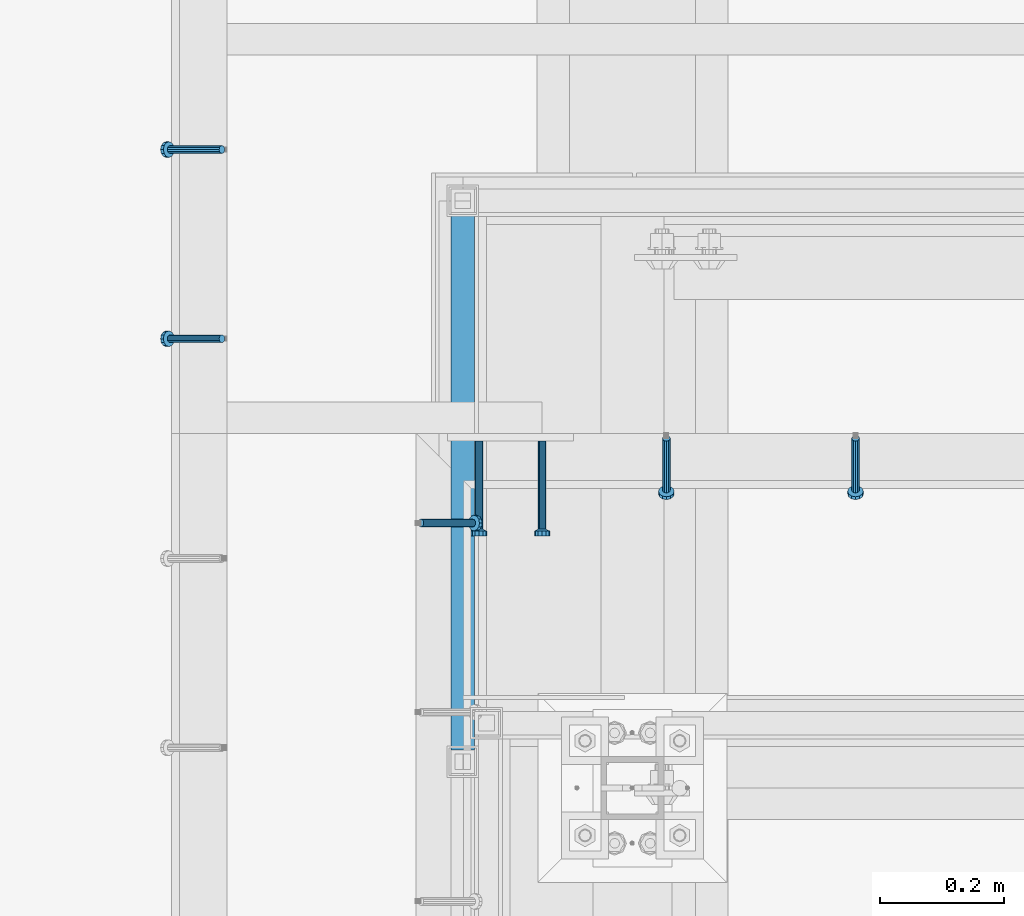
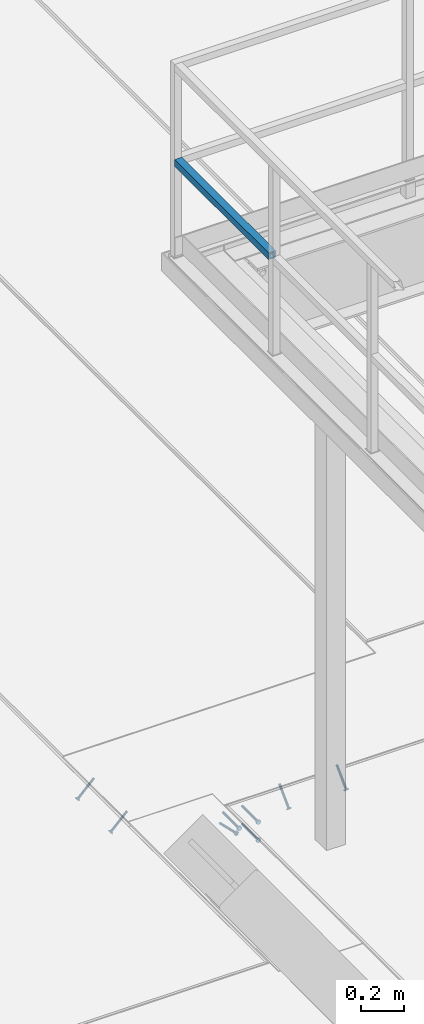
# One storey, part 2117 of 3843: 5 members, 4 beams, 5 elements without a shape of their own.
"""IFC2X3 building model written with IfcOpenShell, lengths in millimetres."""

from ifc_helpers import new_model, si_unit, frame, origin_with_axes, place, context, subcontext, project, spatial, faceted_brep, material, type_object, element, aggregate, save


model = new_model("IFC2X3")

# Units and contexts
model_context = context("Model", 3, precision=1e-05, world=origin_with_axes())
body_context = subcontext(model_context, "Body", "Model", "MODEL_VIEW")
ifc_project = project(units=[si_unit("LENGTHUNIT", "METRE", prefix="MILLI"), si_unit("AREAUNIT", "SQUARE_METRE"), si_unit("VOLUMEUNIT", "CUBIC_METRE"), si_unit("MASSUNIT", "GRAM", prefix="KILO"), si_unit("TIMEUNIT", "SECOND"), si_unit("PLANEANGLEUNIT", "RADIAN"), si_unit("SOLIDANGLEUNIT", "STERADIAN"), si_unit("THERMODYNAMICTEMPERATUREUNIT", "DEGREE_CELSIUS"), si_unit("LUMINOUSINTENSITYUNIT", "LUMEN")], contexts=[model_context])

# Site, building, storey
site_placement = place(None, origin_with_axes())
site = spatial("IfcSite", under=ifc_project, at=site_placement, CompositionType="ELEMENT")
building_placement = place(site_placement, origin_with_axes())
building = spatial("IfcBuilding", under=site, at=building_placement, Name="Undefined", CompositionType="ELEMENT")
storey_placement = place(building_placement, origin_with_axes())
storey = spatial("IfcBuildingStorey", under=building, at=storey_placement, Name="Undefined", CompositionType="ELEMENT", Elevation=0.0)

# Assembly, member
assembly_1_placement = place(storey_placement, origin_with_axes())
assembly_1 = element("IfcElementAssembly", 1, at=assembly_1_placement, inside=storey, Name="EMBED_ANGLE", AssemblyPlace="NOTDEFINED", PredefinedType="RIGID_FRAME")
ifc_material_1 = material(Name="STEEL/A108")
member_type = type_object("IfcMemberType", PredefinedType="NOTDEFINED")
member_1_placement = place(assembly_1_placement, frame((48656.0495, 28024.1375, 30446.6625), z_axis=(0.0, 1.0, 0.0), x_axis=(0.707106781186548, 0.0, -0.707106781186548)))
member_1 = element("IfcMember", 2, at=member_1_placement, type_object=member_type, material=ifc_material_1, Name="HEADED STUD ANCHOR", context=body_context, shape_type="Brep", body=[
    faceted_brep([(7.27595761418343e-12, -3.18000006675175, 5.5), (0.0, -5.49999999998363, 3.1800000667572), (118.110000000976, -5.49999999999091, 3.1800000667572), (118.110000000983, -3.18000006675175, 5.5), (0.0, -6.3499999046162, 0.0), (118.110000000968, -6.34999990461256, 0.0), (0.0, -5.49999999998363, -3.1800000667572), (118.110000000976, -5.49999999999091, -3.1800000667572), (7.27595761418343e-12, -3.18000006675175, -5.5), (118.110000000983, -3.18000006675175, -5.5), (7.27595761418343e-12, -1.81898940354586e-12, -6.34999990463257), (118.110000000968, -1.81898940354586e-12, -6.34999990463257), (0.0, 3.18000006675175, -5.5), (118.110000000968, 3.18000006674811, -5.5), (7.27595761418343e-12, 5.49999999998363, -3.1800000667572), (118.110000000983, 5.49999999998363, -3.1800000667572), (7.27595761418343e-12, 6.3499999046162, 0.0), (118.110000000976, 6.34999990461256, 0.0), (7.27595761418343e-12, 5.49999999998363, 3.1800000667572), (118.110000000983, 5.49999999998363, 3.1800000667572), (0.0, 3.18000006675175, 5.5), (118.110000000968, 3.18000006674811, 5.5), (7.27595761418343e-12, -1.81898940354586e-12, 6.34999990463257), (118.110000000968, -1.81898940354586e-12, 6.34999990463257), (120.650000000991, -10.9899997710909, 6.34999990463257), (120.650000000998, -6.34000015257152, 10.9899997711182), (120.650000000991, -12.6999998092379, 0.0), (120.650000000991, -10.9899997710909, -6.34999990463257), (120.650000000998, -6.34000015257152, -10.9899997711182), (120.650000000991, -1.81898940354586e-12, -12.6899995803833), (120.650000000991, 6.34000015257152, -10.9899997711182), (120.650000000998, 10.9899997710909, -6.34999990463257), (120.650000000991, 12.6999998092342, 0.0), (120.650000000998, 10.9899997710909, 6.34999990463257), (120.650000000991, 6.34000015257152, 10.9899997711182), (120.650000000991, -1.81898940354586e-12, 12.6899995803833), (127.000000001048, -10.9899997710945, 6.34999990463257), (127.000000001048, -6.34000015257152, 10.9899997711182), (127.000000001048, -12.6999998092342, 0.0), (127.000000001048, -10.9899997710945, -6.34999990463257), (127.000000001048, -6.34000015257152, -10.9899997711182), (127.000000001048, 1.81898940354586e-12, -12.6899995803833), (127.000000001048, 6.34000015256788, -10.9899997711182), (127.000000001048, 10.9899997710909, -6.34999990463257), (127.000000001048, 12.6999998092379, 0.0), (127.000000001048, 10.9899997710909, 6.34999990463257), (127.000000001048, 6.34000015256788, 10.9899997711182), (127.000000001048, 1.81898940354586e-12, 12.6899995803833)], [[[0, 1, 2, 3]], [[1, 4, 5, 2]], [[4, 6, 7, 5]], [[6, 8, 9, 7]], [[8, 10, 11, 9]], [[10, 12, 13, 11]], [[12, 14, 15, 13]], [[14, 16, 17, 15]], [[16, 18, 19, 17]], [[18, 20, 21, 19]], [[20, 22, 23, 21]], [[22, 0, 3, 23]], [[22, 20, 18, 16, 14, 12, 10, 8, 6, 4, 1, 0]], [[3, 2, 24, 25]], [[2, 5, 26, 24]], [[5, 7, 27, 26]], [[7, 9, 28, 27]], [[9, 11, 29, 28]], [[11, 13, 30, 29]], [[13, 15, 31, 30]], [[15, 17, 32, 31]], [[17, 19, 33, 32]], [[19, 21, 34, 33]], [[21, 23, 35, 34]], [[23, 3, 25, 35]], [[25, 24, 36, 37]], [[24, 26, 38, 36]], [[26, 27, 39, 38]], [[27, 28, 40, 39]], [[28, 29, 41, 40]], [[29, 30, 42, 41]], [[30, 31, 43, 42]], [[31, 32, 44, 43]], [[32, 33, 45, 44]], [[33, 34, 46, 45]], [[34, 35, 47, 46]], [[35, 25, 37, 47]], [[38, 39, 40, 41, 42, 43, 44, 45, 46, 47, 37, 36]]]),
])
aggregate(assembly_1, [member_1])

# Assembly, members
assembly_2_placement = place(storey_placement, origin_with_axes())
assembly_2 = element("IfcElementAssembly", 3, at=assembly_2_placement, inside=storey, Name="EMBED_ANGLE", AssemblyPlace="NOTDEFINED", PredefinedType="RIGID_FRAME")
member_2_placement = place(assembly_2_placement, frame((49356.137, 28160.6625, 30446.6625), z_axis=(-1.0, 0.0, 0.0), x_axis=(0.0, -0.707106781186548, -0.707106781186548)))
member_2 = element("IfcMember", 4, at=member_2_placement, type_object=member_type, material=ifc_material_1, Name="HEADED STUD ANCHOR", context=body_context, shape_type="Brep", body=[
    faceted_brep([(7.27595761418343e-12, -3.18000006675175, 5.5), (0.0, -5.49999999998363, 3.1800000667572), (118.110000000976, -5.49999999999091, 3.1800000667572), (118.110000000983, -3.18000006675175, 5.5), (0.0, -6.3499999046162, 0.0), (118.110000000968, -6.34999990461256, 0.0), (0.0, -5.49999999998363, -3.1800000667572), (118.110000000976, -5.49999999999091, -3.1800000667572), (7.27595761418343e-12, -3.18000006675175, -5.5), (118.110000000983, -3.18000006675175, -5.5), (7.27595761418343e-12, -1.81898940354586e-12, -6.34999990463257), (118.110000000968, -1.81898940354586e-12, -6.34999990463257), (0.0, 3.18000006675175, -5.5), (118.110000000968, 3.18000006674811, -5.5), (7.27595761418343e-12, 5.49999999998363, -3.1800000667572), (118.110000000983, 5.49999999998363, -3.1800000667572), (7.27595761418343e-12, 6.3499999046162, 0.0), (118.110000000976, 6.34999990461256, 0.0), (7.27595761418343e-12, 5.49999999998363, 3.1800000667572), (118.110000000983, 5.49999999998363, 3.1800000667572), (0.0, 3.18000006675175, 5.5), (118.110000000968, 3.18000006674811, 5.5), (7.27595761418343e-12, -1.81898940354586e-12, 6.34999990463257), (118.110000000968, -1.81898940354586e-12, 6.34999990463257), (120.650000000991, -10.9899997710909, 6.34999990463257), (120.650000000998, -6.34000015257152, 10.9899997711182), (120.650000000991, -12.6999998092379, 0.0), (120.650000000991, -10.9899997710909, -6.34999990463257), (120.650000000998, -6.34000015257152, -10.9899997711182), (120.650000000991, -1.81898940354586e-12, -12.6899995803833), (120.650000000991, 6.34000015257152, -10.9899997711182), (120.650000000998, 10.9899997710909, -6.34999990463257), (120.650000000991, 12.6999998092342, 0.0), (120.650000000998, 10.9899997710909, 6.34999990463257), (120.650000000991, 6.34000015257152, 10.9899997711182), (120.650000000991, -1.81898940354586e-12, 12.6899995803833), (127.000000001048, -10.9899997710945, 6.34999990463257), (127.000000001048, -6.34000015257152, 10.9899997711182), (127.000000001048, -12.6999998092342, 0.0), (127.000000001048, -10.9899997710945, -6.34999990463257), (127.000000001048, -6.34000015257152, -10.9899997711182), (127.000000001048, 1.81898940354586e-12, -12.6899995803833), (127.000000001048, 6.34000015256788, -10.9899997711182), (127.000000001048, 10.9899997710909, -6.34999990463257), (127.000000001048, 12.6999998092379, 0.0), (127.000000001048, 10.9899997710909, 6.34999990463257), (127.000000001048, 6.34000015256788, 10.9899997711182), (127.000000001048, 1.81898940354586e-12, 12.6899995803833)], [[[0, 1, 2, 3]], [[1, 4, 5, 2]], [[4, 6, 7, 5]], [[6, 8, 9, 7]], [[8, 10, 11, 9]], [[10, 12, 13, 11]], [[12, 14, 15, 13]], [[14, 16, 17, 15]], [[16, 18, 19, 17]], [[18, 20, 21, 19]], [[20, 22, 23, 21]], [[22, 0, 3, 23]], [[22, 20, 18, 16, 14, 12, 10, 8, 6, 4, 1, 0]], [[3, 2, 24, 25]], [[2, 5, 26, 24]], [[5, 7, 27, 26]], [[7, 9, 28, 27]], [[9, 11, 29, 28]], [[11, 13, 30, 29]], [[13, 15, 31, 30]], [[15, 17, 32, 31]], [[17, 19, 33, 32]], [[19, 21, 34, 33]], [[21, 23, 35, 34]], [[23, 3, 25, 35]], [[25, 24, 36, 37]], [[24, 26, 38, 36]], [[26, 27, 39, 38]], [[27, 28, 40, 39]], [[28, 29, 41, 40]], [[29, 30, 42, 41]], [[30, 31, 43, 42]], [[31, 32, 44, 43]], [[32, 33, 45, 44]], [[33, 34, 46, 45]], [[34, 35, 47, 46]], [[35, 25, 37, 47]], [[38, 39, 40, 41, 42, 43, 44, 45, 46, 47, 37, 36]]]),
])
member_3_placement = place(assembly_2_placement, frame((49051.337, 28160.6625, 30446.6625), z_axis=(-1.0, 0.0, 0.0), x_axis=(0.0, -0.707106781186548, -0.707106781186548)))
member_3 = element("IfcMember", 5, at=member_3_placement, type_object=member_type, material=ifc_material_1, Name="HEADED STUD ANCHOR", context=body_context, shape_type="Brep", body=[
    faceted_brep([(7.27595761418343e-12, -3.18000006675175, 5.5), (0.0, -5.49999999998363, 3.1800000667572), (118.110000000976, -5.49999999999091, 3.1800000667572), (118.110000000983, -3.18000006675175, 5.5), (0.0, -6.3499999046162, 0.0), (118.110000000968, -6.34999990461256, 0.0), (0.0, -5.49999999998363, -3.1800000667572), (118.110000000976, -5.49999999999091, -3.1800000667572), (7.27595761418343e-12, -3.18000006675175, -5.5), (118.110000000983, -3.18000006675175, -5.5), (7.27595761418343e-12, -1.81898940354586e-12, -6.34999990463257), (118.110000000968, -1.81898940354586e-12, -6.34999990463257), (0.0, 3.18000006675175, -5.5), (118.110000000968, 3.18000006674811, -5.5), (7.27595761418343e-12, 5.49999999998363, -3.1800000667572), (118.110000000983, 5.49999999998363, -3.1800000667572), (7.27595761418343e-12, 6.3499999046162, 0.0), (118.110000000976, 6.34999990461256, 0.0), (7.27595761418343e-12, 5.49999999998363, 3.1800000667572), (118.110000000983, 5.49999999998363, 3.1800000667572), (0.0, 3.18000006675175, 5.5), (118.110000000968, 3.18000006674811, 5.5), (7.27595761418343e-12, -1.81898940354586e-12, 6.34999990463257), (118.110000000968, -1.81898940354586e-12, 6.34999990463257), (120.650000000991, -10.9899997710909, 6.34999990463257), (120.650000000998, -6.34000015257152, 10.9899997711182), (120.650000000991, -12.6999998092379, 0.0), (120.650000000991, -10.9899997710909, -6.34999990463257), (120.650000000998, -6.34000015257152, -10.9899997711182), (120.650000000991, -1.81898940354586e-12, -12.6899995803833), (120.650000000991, 6.34000015257152, -10.9899997711182), (120.650000000998, 10.9899997710909, -6.34999990463257), (120.650000000991, 12.6999998092342, 0.0), (120.650000000998, 10.9899997710909, 6.34999990463257), (120.650000000991, 6.34000015257152, 10.9899997711182), (120.650000000991, -1.81898940354586e-12, 12.6899995803833), (127.000000001048, -10.9899997710945, 6.34999990463257), (127.000000001048, -6.34000015257152, 10.9899997711182), (127.000000001048, -12.6999998092342, 0.0), (127.000000001048, -10.9899997710945, -6.34999990463257), (127.000000001048, -6.34000015257152, -10.9899997711182), (127.000000001048, 1.81898940354586e-12, -12.6899995803833), (127.000000001048, 6.34000015256788, -10.9899997711182), (127.000000001048, 10.9899997710909, -6.34999990463257), (127.000000001048, 12.6999998092379, 0.0), (127.000000001048, 10.9899997710909, 6.34999990463257), (127.000000001048, 6.34000015256788, 10.9899997711182), (127.000000001048, 1.81898940354586e-12, 12.6899995803833)], [[[0, 1, 2, 3]], [[1, 4, 5, 2]], [[4, 6, 7, 5]], [[6, 8, 9, 7]], [[8, 10, 11, 9]], [[10, 12, 13, 11]], [[12, 14, 15, 13]], [[14, 16, 17, 15]], [[16, 18, 19, 17]], [[18, 20, 21, 19]], [[20, 22, 23, 21]], [[22, 0, 3, 23]], [[22, 20, 18, 16, 14, 12, 10, 8, 6, 4, 1, 0]], [[3, 2, 24, 25]], [[2, 5, 26, 24]], [[5, 7, 27, 26]], [[7, 9, 28, 27]], [[9, 11, 29, 28]], [[11, 13, 30, 29]], [[13, 15, 31, 30]], [[15, 17, 32, 31]], [[17, 19, 33, 32]], [[19, 21, 34, 33]], [[21, 23, 35, 34]], [[23, 3, 25, 35]], [[25, 24, 36, 37]], [[24, 26, 38, 36]], [[26, 27, 39, 38]], [[27, 28, 40, 39]], [[28, 29, 41, 40]], [[29, 30, 42, 41]], [[30, 31, 43, 42]], [[31, 32, 44, 43]], [[32, 33, 45, 44]], [[33, 34, 46, 45]], [[34, 35, 47, 46]], [[35, 25, 37, 47]], [[38, 39, 40, 41, 42, 43, 44, 45, 46, 47, 37, 36]]]),
])
aggregate(assembly_2, [member_2, member_3])

assembly_3_placement = place(storey_placement, origin_with_axes())
assembly_3 = element("IfcElementAssembly", 6, at=assembly_3_placement, inside=storey, Name="EMBED_ANGLE", AssemblyPlace="NOTDEFINED", PredefinedType="RIGID_FRAME")
member_4_placement = place(assembly_3_placement, frame((48335.3741210938, 28321.0003845215, 30446.6625), z_axis=(0.0, -1.0, 0.0), x_axis=(-0.707106781186548, 0.0, -0.707106781186548)))
member_4 = element("IfcMember", 7, at=member_4_placement, type_object=member_type, material=ifc_material_1, Name="HEADED STUD ANCHOR", context=body_context, shape_type="Brep", body=[
    faceted_brep([(7.27595761418343e-12, -3.18000006675175, 5.5), (0.0, -5.49999999998363, 3.1800000667572), (118.110000000976, -5.49999999999091, 3.1800000667572), (118.110000000983, -3.18000006675175, 5.5), (0.0, -6.3499999046162, 0.0), (118.110000000968, -6.34999990461256, 0.0), (0.0, -5.49999999998363, -3.1800000667572), (118.110000000976, -5.49999999999091, -3.1800000667572), (7.27595761418343e-12, -3.18000006675175, -5.5), (118.110000000983, -3.18000006675175, -5.5), (7.27595761418343e-12, -1.81898940354586e-12, -6.34999990463257), (118.110000000968, -1.81898940354586e-12, -6.34999990463257), (0.0, 3.18000006675175, -5.5), (118.110000000968, 3.18000006674811, -5.5), (7.27595761418343e-12, 5.49999999998363, -3.1800000667572), (118.110000000983, 5.49999999998363, -3.1800000667572), (7.27595761418343e-12, 6.3499999046162, 0.0), (118.110000000976, 6.34999990461256, 0.0), (7.27595761418343e-12, 5.49999999998363, 3.1800000667572), (118.110000000983, 5.49999999998363, 3.1800000667572), (0.0, 3.18000006675175, 5.5), (118.110000000968, 3.18000006674811, 5.5), (7.27595761418343e-12, -1.81898940354586e-12, 6.34999990463257), (118.110000000968, -1.81898940354586e-12, 6.34999990463257), (120.650000000991, -10.9899997710909, 6.34999990463257), (120.650000000998, -6.34000015257152, 10.9899997711182), (120.650000000991, -12.6999998092379, 0.0), (120.650000000991, -10.9899997710909, -6.34999990463257), (120.650000000998, -6.34000015257152, -10.9899997711182), (120.650000000991, -1.81898940354586e-12, -12.6899995803833), (120.650000000991, 6.34000015257152, -10.9899997711182), (120.650000000998, 10.9899997710909, -6.34999990463257), (120.650000000991, 12.6999998092342, 0.0), (120.650000000998, 10.9899997710909, 6.34999990463257), (120.650000000991, 6.34000015257152, 10.9899997711182), (120.650000000991, -1.81898940354586e-12, 12.6899995803833), (127.000000001048, -10.9899997710945, 6.34999990463257), (127.000000001048, -6.34000015257152, 10.9899997711182), (127.000000001048, -12.6999998092342, 0.0), (127.000000001048, -10.9899997710945, -6.34999990463257), (127.000000001048, -6.34000015257152, -10.9899997711182), (127.000000001048, 1.81898940354586e-12, -12.6899995803833), (127.000000001048, 6.34000015256788, -10.9899997711182), (127.000000001048, 10.9899997710909, -6.34999990463257), (127.000000001048, 12.6999998092379, 0.0), (127.000000001048, 10.9899997710909, 6.34999990463257), (127.000000001048, 6.34000015256788, 10.9899997711182), (127.000000001048, 1.81898940354586e-12, 12.6899995803833)], [[[0, 1, 2, 3]], [[1, 4, 5, 2]], [[4, 6, 7, 5]], [[6, 8, 9, 7]], [[8, 10, 11, 9]], [[10, 12, 13, 11]], [[12, 14, 15, 13]], [[14, 16, 17, 15]], [[16, 18, 19, 17]], [[18, 20, 21, 19]], [[20, 22, 23, 21]], [[22, 0, 3, 23]], [[22, 20, 18, 16, 14, 12, 10, 8, 6, 4, 1, 0]], [[3, 2, 24, 25]], [[2, 5, 26, 24]], [[5, 7, 27, 26]], [[7, 9, 28, 27]], [[9, 11, 29, 28]], [[11, 13, 30, 29]], [[13, 15, 31, 30]], [[15, 17, 32, 31]], [[17, 19, 33, 32]], [[19, 21, 34, 33]], [[21, 23, 35, 34]], [[23, 3, 25, 35]], [[25, 24, 36, 37]], [[24, 26, 38, 36]], [[26, 27, 39, 38]], [[27, 28, 40, 39]], [[28, 29, 41, 40]], [[29, 30, 42, 41]], [[30, 31, 43, 42]], [[31, 32, 44, 43]], [[32, 33, 45, 44]], [[33, 34, 46, 45]], [[34, 35, 47, 46]], [[35, 25, 37, 47]], [[38, 39, 40, 41, 42, 43, 44, 45, 46, 47, 37, 36]]]),
])
member_5_placement = place(assembly_3_placement, frame((48335.3741210938, 28625.8003845215, 30446.6625), z_axis=(0.0, -1.0, 0.0), x_axis=(-0.707106781186548, 0.0, -0.707106781186548)))
member_5 = element("IfcMember", 8, at=member_5_placement, type_object=member_type, material=ifc_material_1, Name="HEADED STUD ANCHOR", context=body_context, shape_type="Brep", body=[
    faceted_brep([(7.27595761418343e-12, -3.18000006675175, 5.5), (0.0, -5.49999999998363, 3.1800000667572), (118.110000000976, -5.49999999999091, 3.1800000667572), (118.110000000983, -3.18000006675175, 5.5), (0.0, -6.3499999046162, 0.0), (118.110000000968, -6.34999990461256, 0.0), (0.0, -5.49999999998363, -3.1800000667572), (118.110000000976, -5.49999999999091, -3.1800000667572), (7.27595761418343e-12, -3.18000006675175, -5.5), (118.110000000983, -3.18000006675175, -5.5), (7.27595761418343e-12, -1.81898940354586e-12, -6.34999990463257), (118.110000000968, -1.81898940354586e-12, -6.34999990463257), (0.0, 3.18000006675175, -5.5), (118.110000000968, 3.18000006674811, -5.5), (7.27595761418343e-12, 5.49999999998363, -3.1800000667572), (118.110000000983, 5.49999999998363, -3.1800000667572), (7.27595761418343e-12, 6.3499999046162, 0.0), (118.110000000976, 6.34999990461256, 0.0), (7.27595761418343e-12, 5.49999999998363, 3.1800000667572), (118.110000000983, 5.49999999998363, 3.1800000667572), (0.0, 3.18000006675175, 5.5), (118.110000000968, 3.18000006674811, 5.5), (7.27595761418343e-12, -1.81898940354586e-12, 6.34999990463257), (118.110000000968, -1.81898940354586e-12, 6.34999990463257), (120.650000000991, -10.9899997710909, 6.34999990463257), (120.650000000998, -6.34000015257152, 10.9899997711182), (120.650000000991, -12.6999998092379, 0.0), (120.650000000991, -10.9899997710909, -6.34999990463257), (120.650000000998, -6.34000015257152, -10.9899997711182), (120.650000000991, -1.81898940354586e-12, -12.6899995803833), (120.650000000991, 6.34000015257152, -10.9899997711182), (120.650000000998, 10.9899997710909, -6.34999990463257), (120.650000000991, 12.6999998092342, 0.0), (120.650000000998, 10.9899997710909, 6.34999990463257), (120.650000000991, 6.34000015257152, 10.9899997711182), (120.650000000991, -1.81898940354586e-12, 12.6899995803833), (127.000000001048, -10.9899997710945, 6.34999990463257), (127.000000001048, -6.34000015257152, 10.9899997711182), (127.000000001048, -12.6999998092342, 0.0), (127.000000001048, -10.9899997710945, -6.34999990463257), (127.000000001048, -6.34000015257152, -10.9899997711182), (127.000000001048, 1.81898940354586e-12, -12.6899995803833), (127.000000001048, 6.34000015256788, -10.9899997711182), (127.000000001048, 10.9899997710909, -6.34999990463257), (127.000000001048, 12.6999998092379, 0.0), (127.000000001048, 10.9899997710909, 6.34999990463257), (127.000000001048, 6.34000015256788, 10.9899997711182), (127.000000001048, 1.81898940354586e-12, 12.6899995803833)], [[[0, 1, 2, 3]], [[1, 4, 5, 2]], [[4, 6, 7, 5]], [[6, 8, 9, 7]], [[8, 10, 11, 9]], [[10, 12, 13, 11]], [[12, 14, 15, 13]], [[14, 16, 17, 15]], [[16, 18, 19, 17]], [[18, 20, 21, 19]], [[20, 22, 23, 21]], [[22, 0, 3, 23]], [[22, 20, 18, 16, 14, 12, 10, 8, 6, 4, 1, 0]], [[3, 2, 24, 25]], [[2, 5, 26, 24]], [[5, 7, 27, 26]], [[7, 9, 28, 27]], [[9, 11, 29, 28]], [[11, 13, 30, 29]], [[13, 15, 31, 30]], [[15, 17, 32, 31]], [[17, 19, 33, 32]], [[19, 21, 34, 33]], [[21, 23, 35, 34]], [[23, 3, 25, 35]], [[25, 24, 36, 37]], [[24, 26, 38, 36]], [[26, 27, 39, 38]], [[27, 28, 40, 39]], [[28, 29, 41, 40]], [[29, 30, 42, 41]], [[30, 31, 43, 42]], [[31, 32, 44, 43]], [[32, 33, 45, 44]], [[33, 34, 46, 45]], [[34, 35, 47, 46]], [[35, 25, 37, 47]], [[38, 39, 40, 41, 42, 43, 44, 45, 46, 47, 37, 36]]]),
])
aggregate(assembly_3, [member_4, member_5])

# Assembly, beam
assembly_4_placement = place(storey_placement, origin_with_axes())
assembly_4 = element("IfcElementAssembly", 9, at=assembly_4_placement, inside=storey, Name="RAIL", AssemblyPlace="NOTDEFINED", PredefinedType="RIGID_FRAME")
ifc_material_2 = material()
beam_type_1 = type_object("IfcBeamType", Name="HSS1-1/2X1-1/2X1/4", PredefinedType="NOTDEFINED")
beam_1_placement = place(assembly_4_placement, frame((48723.549999976, 28543.25, 33832.8000002631), z_axis=(0.0, 0.0, 1.0), x_axis=(0.0, -1.0, 0.0)))
beam_1 = element("IfcBeam", 10, at=beam_1_placement, type_object=beam_type_1, material=ifc_material_2, Name="RAIL", ObjectType="HSS1-1/2X1-1/2X1/4", context=body_context, shape_type="Brep", body=[
    faceted_brep([(19.0499992350015, 12.6999993299978, -12.6999993299978), (19.0499992350015, -12.6999993299978, -12.6999993299978), (884.766667431661, -12.6999993299978, -12.6999993299978), (884.766667431661, 12.6999993299978, -12.6999993299978), (19.0499992350015, -12.6999993299978, 12.6999993299978), (884.766667431661, -12.6999993299978, 12.6999993299978), (19.0499992350015, 12.6999993299978, 12.6999993299978), (884.766667431661, 12.6999993299978, 12.6999993299978), (19.0499992350015, 19.0499992350015, -19.0499992350015), (19.0499992350015, 19.0499992350015, 19.0499992350015), (884.766667431661, 19.0499992350015, 19.0499992350015), (884.766667431661, 19.0499992350015, -19.0499992350015), (19.0499992350015, -19.0499992350015, 19.0499992350015), (884.766667431661, -19.0499992350015, 19.0499992350015), (19.0499992350015, -19.0499992350015, -19.0499992350015), (884.766667431661, -19.0499992350015, -19.0499992350015)], [[[0, 1, 2, 3]], [[1, 4, 5, 2]], [[4, 6, 7, 5]], [[6, 0, 3, 7]], [[8, 9, 10, 11]], [[9, 12, 13, 10]], [[12, 14, 15, 13]], [[14, 8, 11, 15]], [[13, 15, 11, 10], [5, 7, 3, 2]], [[14, 12, 9, 8], [6, 4, 1, 0]]]),
])
aggregate(assembly_4, [beam_1])

# Assembly, beams
assembly_5_placement = place(storey_placement, origin_with_axes())
assembly_5 = element("IfcElementAssembly", 11, at=assembly_5_placement, inside=storey, Name="EMBED PLATE", AssemblyPlace="NOTDEFINED", PredefinedType="RIGID_FRAME")
beam_type_2 = type_object("IfcBeamType", PredefinedType="NOTDEFINED")
beam_2_placement = place(assembly_5_placement, frame((48851.312, 28155.9, 30394.275), z_axis=(1.0, 0.0, 0.0), x_axis=(0.0, -1.0, 0.0)))
beam_2 = element("IfcBeam", 12, at=beam_2_placement, type_object=beam_type_2, material=ifc_material_1, Name="HEADED STUD ANCHOR", context=body_context, shape_type="Brep", body=[
    faceted_brep([(7.27595761418343e-12, -3.18000006675175, 5.5), (0.0, -5.49999999998363, 3.1800000667572), (141.731999999989, -5.5, 3.1800000667572), (141.731999999989, -3.1800000667572, 5.5), (0.0, -6.3499999046162, 0.0), (141.731999999989, -6.34999990463257, 0.0), (0.0, -5.49999999998363, -3.1800000667572), (141.731999999989, -5.5, -3.1800000667572), (7.27595761418343e-12, -3.18000006675175, -5.5), (141.731999999989, -3.1800000667572, -5.5), (7.27595761418343e-12, -1.81898940354586e-12, -6.34999990463257), (141.731999999989, 0.0, -6.34999990463257), (0.0, 3.18000006675175, -5.5), (141.731999999989, 3.1800000667572, -5.5), (7.27595761418343e-12, 5.49999999998363, -3.1800000667572), (141.731999999989, 5.5, -3.1800000667572), (7.27595761418343e-12, 6.3499999046162, 0.0), (141.731999999989, 6.34999990463257, 0.0), (7.27595761418343e-12, 5.49999999998363, 3.1800000667572), (141.731999999989, 5.5, 3.1800000667572), (0.0, 3.18000006675175, 5.5), (141.731999999989, 3.1800000667572, 5.5), (7.27595761418343e-12, -1.81898940354586e-12, 6.34999990463257), (141.731999999989, 0.0, 6.34999990463257), (144.779999999999, -10.9899997711182, 6.34999990463257), (144.779999999999, -6.34000015258789, 10.9899997711182), (144.779999999999, -12.6999998092651, 0.0), (144.779999999999, -10.9899997711182, -6.34999990463257), (144.779999999999, -6.34000015258789, -10.9899997711182), (144.779999999999, 0.0, -12.6899995803833), (144.779999999999, 6.34000015258789, -10.9899997711182), (144.779999999999, 10.9899997711182, -6.34999990463257), (144.779999999999, 12.6999998092651, 0.0), (144.779999999999, 10.9899997711182, 6.34999990463257), (144.779999999999, 6.34000015258789, 10.9899997711182), (144.779999999999, 0.0, 12.6899995803833), (152.399999999994, -10.9899997711182, 6.34999990463257), (152.399999999994, -6.34000015258789, 10.9899997711182), (152.399999999994, -12.6999998092651, 0.0), (152.399999999994, -10.9899997711182, -6.34999990463257), (152.399999999994, -6.34000015258789, -10.9899997711182), (152.399999999994, 0.0, -12.6899995803833), (152.399999999994, 6.34000015258789, -10.9899997711182), (152.399999999994, 10.9899997711182, -6.34999990463257), (152.399999999994, 12.6999998092651, 0.0), (152.399999999994, 10.9899997711182, 6.34999990463257), (152.399999999994, 6.34000015258789, 10.9899997711182), (152.399999999994, 0.0, 12.6899995803833)], [[[0, 1, 2, 3]], [[1, 4, 5, 2]], [[4, 6, 7, 5]], [[6, 8, 9, 7]], [[8, 10, 11, 9]], [[10, 12, 13, 11]], [[12, 14, 15, 13]], [[14, 16, 17, 15]], [[16, 18, 19, 17]], [[18, 20, 21, 19]], [[20, 22, 23, 21]], [[22, 0, 3, 23]], [[22, 20, 18, 16, 14, 12, 10, 8, 6, 4, 1, 0]], [[3, 2, 24, 25]], [[2, 5, 26, 24]], [[5, 7, 27, 26]], [[7, 9, 28, 27]], [[9, 11, 29, 28]], [[11, 13, 30, 29]], [[13, 15, 31, 30]], [[15, 17, 32, 31]], [[17, 19, 33, 32]], [[19, 21, 34, 33]], [[21, 23, 35, 34]], [[23, 3, 25, 35]], [[25, 24, 36, 37]], [[24, 26, 38, 36]], [[26, 27, 39, 38]], [[27, 28, 40, 39]], [[28, 29, 41, 40]], [[29, 30, 42, 41]], [[30, 31, 43, 42]], [[31, 32, 44, 43]], [[32, 33, 45, 44]], [[33, 34, 46, 45]], [[34, 35, 47, 46]], [[35, 25, 37, 47]], [[38, 39, 40, 41, 42, 43, 44, 45, 46, 47, 37, 36]]]),
])
beam_3_placement = place(assembly_5_placement, frame((48851.312, 28155.9, 30292.675), z_axis=(1.0, 0.0, 0.0), x_axis=(0.0, -1.0, 0.0)))
beam_3 = element("IfcBeam", 13, at=beam_3_placement, type_object=beam_type_2, material=ifc_material_1, Name="HEADED STUD ANCHOR", context=body_context, shape_type="Brep", body=[
    faceted_brep([(7.27595761418343e-12, -3.18000006675175, 5.5), (0.0, -5.49999999998363, 3.1800000667572), (141.731999999989, -5.5, 3.1800000667572), (141.731999999989, -3.1800000667572, 5.5), (0.0, -6.3499999046162, 0.0), (141.731999999989, -6.34999990463257, 0.0), (0.0, -5.49999999998363, -3.1800000667572), (141.731999999989, -5.5, -3.1800000667572), (7.27595761418343e-12, -3.18000006675175, -5.5), (141.731999999989, -3.1800000667572, -5.5), (7.27595761418343e-12, -1.81898940354586e-12, -6.34999990463257), (141.731999999989, 0.0, -6.34999990463257), (0.0, 3.18000006675175, -5.5), (141.731999999989, 3.1800000667572, -5.5), (7.27595761418343e-12, 5.49999999998363, -3.1800000667572), (141.731999999989, 5.5, -3.1800000667572), (7.27595761418343e-12, 6.3499999046162, 0.0), (141.731999999989, 6.34999990463257, 0.0), (7.27595761418343e-12, 5.49999999998363, 3.1800000667572), (141.731999999989, 5.5, 3.1800000667572), (0.0, 3.18000006675175, 5.5), (141.731999999989, 3.1800000667572, 5.5), (7.27595761418343e-12, -1.81898940354586e-12, 6.34999990463257), (141.731999999989, 0.0, 6.34999990463257), (144.779999999999, -10.9899997711182, 6.34999990463257), (144.779999999999, -6.34000015258789, 10.9899997711182), (144.779999999999, -12.6999998092651, 0.0), (144.779999999999, -10.9899997711182, -6.34999990463257), (144.779999999999, -6.34000015258789, -10.9899997711182), (144.779999999999, 0.0, -12.6899995803833), (144.779999999999, 6.34000015258789, -10.9899997711182), (144.779999999999, 10.9899997711182, -6.34999990463257), (144.779999999999, 12.6999998092651, 0.0), (144.779999999999, 10.9899997711182, 6.34999990463257), (144.779999999999, 6.34000015258789, 10.9899997711182), (144.779999999999, 0.0, 12.6899995803833), (152.399999999994, -10.9899997711182, 6.34999990463257), (152.399999999994, -6.34000015258789, 10.9899997711182), (152.399999999994, -12.6999998092651, 0.0), (152.399999999994, -10.9899997711182, -6.34999990463257), (152.399999999994, -6.34000015258789, -10.9899997711182), (152.399999999994, 0.0, -12.6899995803833), (152.399999999994, 6.34000015258789, -10.9899997711182), (152.399999999994, 10.9899997711182, -6.34999990463257), (152.399999999994, 12.6999998092651, 0.0), (152.399999999994, 10.9899997711182, 6.34999990463257), (152.399999999994, 6.34000015258789, 10.9899997711182), (152.399999999994, 0.0, 12.6899995803833)], [[[0, 1, 2, 3]], [[1, 4, 5, 2]], [[4, 6, 7, 5]], [[6, 8, 9, 7]], [[8, 10, 11, 9]], [[10, 12, 13, 11]], [[12, 14, 15, 13]], [[14, 16, 17, 15]], [[16, 18, 19, 17]], [[18, 20, 21, 19]], [[20, 22, 23, 21]], [[22, 0, 3, 23]], [[22, 20, 18, 16, 14, 12, 10, 8, 6, 4, 1, 0]], [[3, 2, 24, 25]], [[2, 5, 26, 24]], [[5, 7, 27, 26]], [[7, 9, 28, 27]], [[9, 11, 29, 28]], [[11, 13, 30, 29]], [[13, 15, 31, 30]], [[15, 17, 32, 31]], [[17, 19, 33, 32]], [[19, 21, 34, 33]], [[21, 23, 35, 34]], [[23, 3, 25, 35]], [[25, 24, 36, 37]], [[24, 26, 38, 36]], [[26, 27, 39, 38]], [[27, 28, 40, 39]], [[28, 29, 41, 40]], [[29, 30, 42, 41]], [[30, 31, 43, 42]], [[31, 32, 44, 43]], [[32, 33, 45, 44]], [[33, 34, 46, 45]], [[34, 35, 47, 46]], [[35, 25, 37, 47]], [[38, 39, 40, 41, 42, 43, 44, 45, 46, 47, 37, 36]]]),
])
beam_4_placement = place(assembly_5_placement, frame((48749.712, 28155.9, 30394.275), z_axis=(1.0, 0.0, 0.0), x_axis=(0.0, -1.0, 0.0)))
beam_4 = element("IfcBeam", 14, at=beam_4_placement, type_object=beam_type_2, material=ifc_material_1, Name="HEADED STUD ANCHOR", context=body_context, shape_type="Brep", body=[
    faceted_brep([(7.27595761418343e-12, -3.18000006675175, 5.5), (0.0, -5.49999999998363, 3.1800000667572), (141.731999999989, -5.5, 3.1800000667572), (141.731999999989, -3.1800000667572, 5.5), (0.0, -6.3499999046162, 0.0), (141.731999999989, -6.34999990463257, 0.0), (0.0, -5.49999999998363, -3.1800000667572), (141.731999999989, -5.5, -3.1800000667572), (7.27595761418343e-12, -3.18000006675175, -5.5), (141.731999999989, -3.1800000667572, -5.5), (7.27595761418343e-12, -1.81898940354586e-12, -6.34999990463257), (141.731999999989, 0.0, -6.34999990463257), (0.0, 3.18000006675175, -5.5), (141.731999999989, 3.1800000667572, -5.5), (7.27595761418343e-12, 5.49999999998363, -3.1800000667572), (141.731999999989, 5.5, -3.1800000667572), (7.27595761418343e-12, 6.3499999046162, 0.0), (141.731999999989, 6.34999990463257, 0.0), (7.27595761418343e-12, 5.49999999998363, 3.1800000667572), (141.731999999989, 5.5, 3.1800000667572), (0.0, 3.18000006675175, 5.5), (141.731999999989, 3.1800000667572, 5.5), (7.27595761418343e-12, -1.81898940354586e-12, 6.34999990463257), (141.731999999989, 0.0, 6.34999990463257), (144.779999999999, -10.9899997711182, 6.34999990463257), (144.779999999999, -6.34000015258789, 10.9899997711182), (144.779999999999, -12.6999998092651, 0.0), (144.779999999999, -10.9899997711182, -6.34999990463257), (144.779999999999, -6.34000015258789, -10.9899997711182), (144.779999999999, 0.0, -12.6899995803833), (144.779999999999, 6.34000015258789, -10.9899997711182), (144.779999999999, 10.9899997711182, -6.34999990463257), (144.779999999999, 12.6999998092651, 0.0), (144.779999999999, 10.9899997711182, 6.34999990463257), (144.779999999999, 6.34000015258789, 10.9899997711182), (144.779999999999, 0.0, 12.6899995803833), (152.399999999994, -10.9899997711182, 6.34999990463257), (152.399999999994, -6.34000015258789, 10.9899997711182), (152.399999999994, -12.6999998092651, 0.0), (152.399999999994, -10.9899997711182, -6.34999990463257), (152.399999999994, -6.34000015258789, -10.9899997711182), (152.399999999994, 0.0, -12.6899995803833), (152.399999999994, 6.34000015258789, -10.9899997711182), (152.399999999994, 10.9899997711182, -6.34999990463257), (152.399999999994, 12.6999998092651, 0.0), (152.399999999994, 10.9899997711182, 6.34999990463257), (152.399999999994, 6.34000015258789, 10.9899997711182), (152.399999999994, 0.0, 12.6899995803833)], [[[0, 1, 2, 3]], [[1, 4, 5, 2]], [[4, 6, 7, 5]], [[6, 8, 9, 7]], [[8, 10, 11, 9]], [[10, 12, 13, 11]], [[12, 14, 15, 13]], [[14, 16, 17, 15]], [[16, 18, 19, 17]], [[18, 20, 21, 19]], [[20, 22, 23, 21]], [[22, 0, 3, 23]], [[22, 20, 18, 16, 14, 12, 10, 8, 6, 4, 1, 0]], [[3, 2, 24, 25]], [[2, 5, 26, 24]], [[5, 7, 27, 26]], [[7, 9, 28, 27]], [[9, 11, 29, 28]], [[11, 13, 30, 29]], [[13, 15, 31, 30]], [[15, 17, 32, 31]], [[17, 19, 33, 32]], [[19, 21, 34, 33]], [[21, 23, 35, 34]], [[23, 3, 25, 35]], [[25, 24, 36, 37]], [[24, 26, 38, 36]], [[26, 27, 39, 38]], [[27, 28, 40, 39]], [[28, 29, 41, 40]], [[29, 30, 42, 41]], [[30, 31, 43, 42]], [[31, 32, 44, 43]], [[32, 33, 45, 44]], [[33, 34, 46, 45]], [[34, 35, 47, 46]], [[35, 25, 37, 47]], [[38, 39, 40, 41, 42, 43, 44, 45, 46, 47, 37, 36]]]),
])
aggregate(assembly_5, [beam_2, beam_3, beam_4])

save(model, "model.ifc")
